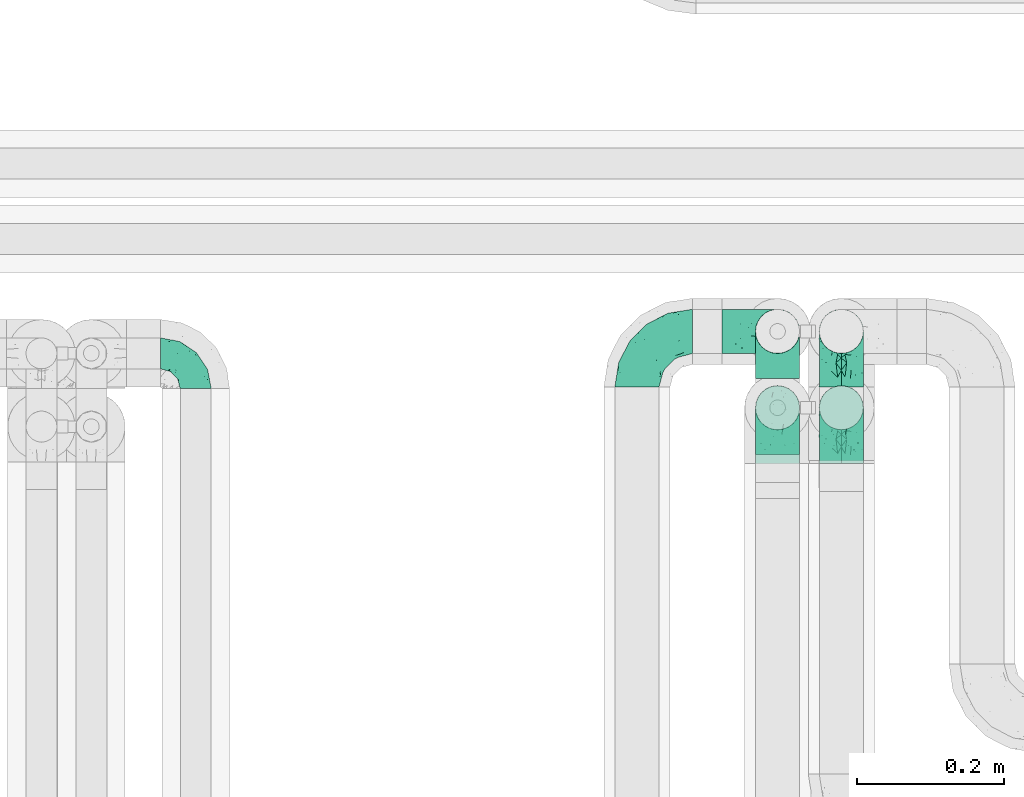
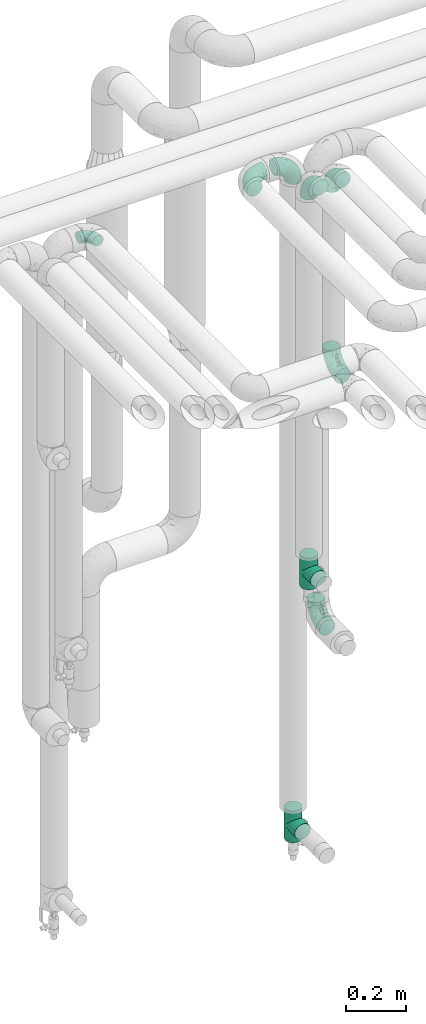
# One storey, part 639 of 827: 9 flow fittings.
"""IFC2X3 building model written with IfcOpenShell, lengths in millimetres."""

from ifc_helpers import new_model, entity, si_unit, converted_unit, derived_unit, direction, frame, origin, place, context, subcontext, project, spatial, faceted_brep, source, transform, mapped, material, type_object, type_shapes, element, save


model = new_model("IFC2X3")

# Units and contexts
model_context = context("Model", 3, precision=0.01, world=origin(), true_north=direction((6.12303176911189e-17, 1.0)))
body_context = subcontext(model_context, "Body", "Model", "MODEL_VIEW")
ifc_project = project(units=[si_unit("LENGTHUNIT", "METRE", prefix="MILLI"), si_unit("AREAUNIT", "SQUARE_METRE"), si_unit("VOLUMEUNIT", "CUBIC_METRE"), converted_unit("PLANEANGLEUNIT", "DEGREE", entity("IfcRatioMeasure", 0.0174532925199433), si_unit("PLANEANGLEUNIT", "RADIAN"), dimensions=[0, 0, 0, 0, 0, 0, 0]), si_unit("MASSUNIT", "GRAM", prefix="KILO"), derived_unit("MASSDENSITYUNIT", [(si_unit("MASSUNIT", "GRAM", prefix="KILO"), 1), (si_unit("LENGTHUNIT", "METRE"), -3)]), derived_unit("MOMENTOFINERTIAUNIT", [(si_unit("LENGTHUNIT", "METRE"), 4)]), si_unit("TIMEUNIT", "SECOND"), si_unit("FREQUENCYUNIT", "HERTZ"), si_unit("THERMODYNAMICTEMPERATUREUNIT", "DEGREE_CELSIUS"), derived_unit("THERMALTRANSMITTANCEUNIT", [(si_unit("MASSUNIT", "GRAM", prefix="KILO"), 1), (si_unit("THERMODYNAMICTEMPERATUREUNIT", "KELVIN"), -1), (si_unit("TIMEUNIT", "SECOND"), -3)]), derived_unit("VOLUMETRICFLOWRATEUNIT", [(si_unit("LENGTHUNIT", "METRE"), 3), (si_unit("TIMEUNIT", "SECOND"), -1)]), derived_unit("MASSFLOWRATEUNIT", [(si_unit("MASSUNIT", "GRAM", prefix="KILO"), 1), (si_unit("TIMEUNIT", "SECOND"), -1)]), derived_unit("ROTATIONALFREQUENCYUNIT", [(si_unit("TIMEUNIT", "SECOND"), -1)]), si_unit("ELECTRICCURRENTUNIT", "AMPERE"), si_unit("ELECTRICVOLTAGEUNIT", "VOLT"), si_unit("POWERUNIT", "WATT"), si_unit("FORCEUNIT", "NEWTON", prefix="KILO"), si_unit("ILLUMINANCEUNIT", "LUX"), si_unit("LUMINOUSFLUXUNIT", "LUMEN"), si_unit("LUMINOUSINTENSITYUNIT", "CANDELA"), derived_unit("USERDEFINED", [(si_unit("MASSUNIT", "GRAM", prefix="KILO"), -1), (si_unit("LENGTHUNIT", "METRE"), -2), (si_unit("TIMEUNIT", "SECOND"), 3), (si_unit("LUMINOUSFLUXUNIT", "LUMEN"), 1)]), derived_unit("LINEARVELOCITYUNIT", [(si_unit("LENGTHUNIT", "METRE"), 1), (si_unit("TIMEUNIT", "SECOND"), -1)]), si_unit("PRESSUREUNIT", "PASCAL"), derived_unit("USERDEFINED", [(si_unit("LENGTHUNIT", "METRE"), -2), (si_unit("MASSUNIT", "GRAM", prefix="KILO"), 1), (si_unit("TIMEUNIT", "SECOND"), -2)]), derived_unit("LINEARFORCEUNIT", [(si_unit("MASSUNIT", "GRAM", prefix="KILO"), 1), (si_unit("LENGTHUNIT", "METRE"), 1), (si_unit("TIMEUNIT", "SECOND"), -2), (si_unit("LENGTHUNIT", "METRE"), -1)]), derived_unit("PLANARFORCEUNIT", [(si_unit("MASSUNIT", "GRAM", prefix="KILO"), 1), (si_unit("LENGTHUNIT", "METRE"), 1), (si_unit("TIMEUNIT", "SECOND"), -2), (si_unit("LENGTHUNIT", "METRE"), -2)])], contexts=[model_context])

# Site, building, storey
site_placement = place(None, origin())
site = spatial("IfcSite", under=ifc_project, at=site_placement, CompositionType="ELEMENT")
building_placement = place(site_placement, origin())
building = spatial("IfcBuilding", under=site, at=building_placement, CompositionType="ELEMENT")
storey_placement = place(building_placement, frame((0.0, 0.0, 28200.0)))
storey = spatial("IfcBuildingStorey", under=building, at=storey_placement, Name="08", CompositionType="ELEMENT", Elevation=28200.0)

# Flow fittings
ifc_material = material()
pipe_fitting_type_1 = type_object("IfcPipeFittingType", Name="ADSK_1", PredefinedType="NOTDEFINED", material=ifc_material)
shared_shape_1 = source(origin(), body_context, "Body", "Brep", [
    faceted_brep([(-48.0, 10.6, -18.36), (-48.0, 5.49, -20.48), (-48.0, 0.0, -21.2), (-48.0, -5.49, -20.48), (-48.0, -10.6, -18.36), (-48.0, -14.99, -14.99), (-48.0, -18.36, -10.6), (-48.0, -20.48, -5.49), (-48.0, -21.2, 0.0), (-48.0, -20.48, 5.49), (-48.0, -18.36, 10.6), (-48.0, -14.99, 14.99), (-48.0, -10.6, 18.36), (-48.0, -5.49, 20.48), (-48.0, 0.0, 21.2), (-48.0, 5.49, 20.48), (-48.0, 10.6, 18.36), (-48.0, 14.99, 14.99), (-48.0, 18.36, 10.6), (-48.0, 20.48, 5.49), (-48.0, 21.2, 0.0), (-48.0, 20.48, -5.49), (-48.0, 18.36, -10.6), (-48.0, 14.99, -14.99), (0.0, 48.0, -21.2), (-5.49, 48.0, -20.48), (-10.6, 48.0, -18.36), (-14.99, 48.0, -14.99), (-18.36, 48.0, -10.6), (-20.48, 48.0, -5.49), (-21.2, 48.0, 0.0), (-20.48, 48.0, 5.49), (-18.36, 48.0, 10.6), (-14.99, 48.0, 14.99), (-10.6, 48.0, 18.36), (-5.49, 48.0, 20.48), (0.0, 48.0, 21.2), (5.49, 48.0, 20.48), (10.6, 48.0, 18.36), (14.99, 48.0, 14.99), (18.36, 48.0, 10.6), (20.48, 48.0, 5.49), (21.2, 48.0, 0.0), (20.48, 48.0, -5.49), (18.36, 48.0, -10.6), (14.99, 48.0, -14.99), (10.6, 48.0, -18.36), (5.49, 48.0, -20.48), (-35.25, -16.22, 12.01), (-34.76, -18.57, 0.0), (-20.87, -12.37, 10.9), (-31.49, -11.78, 15.9), (-37.0, -2.58, 20.86), (-33.89, 3.62, 21.15), (-31.81, -18.14, 6.76), (-5.78, 5.78, 17.67), (-19.42, -4.1, 17.86), (-9.6, -3.39, 13.73), (-35.44, -7.73, 19.13), (11.78, 31.49, 15.9), (-5.93, -5.46, 6.95), (-18.45, -13.78, 5.46), (-10.29, -8.43, 0.0), (-24.6, 0.55, 20.62), (-37.28, 17.94, 13.81), (-33.38, 22.85, 9.59), (-41.46, 20.06, 8.75), (-29.51, 20.45, 15.16), (-15.04, 10.79, 21.13), (-7.08, 16.98, 20.93), (-8.39, 23.51, 21.15), (-40.86, 13.03, 17.26), (-8.05, 41.26, 19.83), (-3.21, 35.97, 21.14), (8.53, 19.66, 14.74), (4.1, 19.42, 17.86), (-37.72, 22.66, 4.78), (-37.07, 8.58, 19.98), (-13.0, 5.43, 19.97), (-3.78, 13.93, 19.7), (3.02, 8.69, 13.43), (-2.27, -0.05, 10.65), (6.22, 6.99, 7.09), (-22.25, 34.6, 9.45), (18.14, 31.81, 6.76), (16.22, 35.25, 12.01), (12.37, 20.87, 10.9), (7.73, 35.44, 19.13), (-21.52, -15.93, 0.0), (2.58, 37.0, 20.86), (18.57, 34.76, 0.0), (13.78, 18.45, 5.46), (15.93, 21.52, 0.0), (-20.03, -8.54, 14.9), (-28.6, 28.6, 5.16), (-24.79, 34.6, 0.0), (-34.6, 24.79, 0.0), (-22.81, 37.41, 4.68), (-23.36, 26.33, 14.79), (-13.68, 37.05, 17.49), (-17.72, 38.12, 13.73), (-26.25, 27.3, 11.24), (-9.71, 32.34, 20.14), (-17.26, 25.6, 18.71), (-26.33, 9.99, 20.77), (-24.06, 6.05, 21.2), (-25.02, 15.46, 19.56), (-24.3, 20.72, 17.57), (-31.95, 15.23, 17.8), (-13.53, 24.7, 20.21), (-17.6, 17.6, 20.6), (-0.55, 24.6, 20.62), (-11.41, -7.48, 10.43), (0.93, -0.93, 0.0), (8.43, 10.29, 0.0), (-11.41, -7.48, -10.43), (-20.1, -8.84, -14.66), (-9.6, -3.39, -13.73), (7.73, 35.44, -19.13), (4.1, 19.42, -17.86), (-0.55, 24.6, -20.62), (-38.12, 17.72, -13.73), (-37.05, 13.68, -17.49), (-32.34, 9.71, -20.14), (-41.26, 8.05, -19.83), (-37.41, 22.81, -4.68), (-23.51, 8.39, -21.15), (-35.97, 3.21, -21.14), (-28.6, 28.6, -5.16), (-31.81, -18.14, -6.76), (-18.45, -13.78, -5.46), (-25.6, 17.26, -18.71), (-19.42, -4.1, -17.86), (-17.94, 37.28, -13.81), (-22.85, 33.38, -9.59), (-20.06, 41.46, -8.75), (-31.49, -11.78, -15.9), (-35.25, -16.22, -12.01), (8.53, 19.66, -14.74), (11.78, 31.49, -15.9), (-9.99, 26.33, -20.77), (-6.05, 24.06, -21.2), (-10.79, 15.04, -21.13), (-37.0, -2.58, -20.86), (-16.98, 7.08, -20.93), (-5.43, 13.0, -19.97), (-13.93, 3.78, -19.7), (-20.87, -12.37, -10.9), (-26.33, 23.36, -14.79), (-22.66, 37.72, -4.78), (13.78, 18.45, -5.46), (18.14, 31.81, -6.76), (-15.46, 25.02, -19.56), (-20.72, 24.3, -17.57), (16.22, 35.25, -12.01), (-13.03, 40.86, -17.26), (-8.58, 37.07, -19.98), (2.58, 37.0, -20.86), (-3.62, 33.89, -21.15), (-34.6, 22.25, -9.45), (6.22, 6.99, -7.09), (-20.45, 29.51, -15.16), (-35.44, -7.73, -19.13), (12.37, 20.87, -10.9), (-27.3, 26.25, -11.24), (-15.23, 31.95, -17.8), (-24.7, 13.53, -20.21), (-24.6, 0.55, -20.62), (-5.78, 5.78, -17.67), (-17.6, 17.6, -20.6), (3.02, 8.69, -13.43), (-5.93, -5.46, -6.95), (-2.27, -0.05, -10.65)], [[[0, 1, 2, 3, 4, 5, 6, 7, 8, 9, 10, 11, 12, 13, 14, 15, 16, 17, 18, 19, 20, 21, 22, 23]], [[24, 25, 26, 27, 28, 29, 30, 31, 32, 33, 34, 35, 36, 37, 38, 39, 40, 41, 42, 43, 44, 45, 46, 47]], [[10, 48, 11]], [[9, 8, 49]], [[48, 50, 51]], [[14, 52, 53]], [[10, 54, 48]], [[9, 54, 10]], [[55, 56, 57]], [[51, 12, 11]], [[51, 58, 12]], [[59, 39, 38]], [[60, 61, 62]], [[58, 56, 63]], [[64, 65, 66]], [[67, 65, 64]], [[68, 69, 70]], [[16, 71, 17]], [[13, 52, 14]], [[35, 72, 73]], [[14, 53, 15]], [[17, 64, 18]], [[74, 59, 75]], [[20, 19, 76]], [[66, 19, 18]], [[77, 15, 53]], [[15, 77, 16]], [[69, 78, 79]], [[80, 81, 82]], [[32, 31, 83]], [[84, 85, 86]], [[59, 87, 75]], [[61, 54, 88]], [[36, 89, 37]], [[84, 41, 40]], [[36, 35, 73]], [[90, 41, 84]], [[40, 39, 85]], [[12, 58, 13]], [[85, 84, 40]], [[91, 84, 86]], [[84, 92, 90]], [[87, 38, 37]], [[93, 56, 51]], [[65, 94, 76]], [[94, 95, 96]], [[84, 91, 92]], [[95, 97, 30]], [[98, 99, 100]], [[76, 94, 96]], [[101, 98, 83]], [[100, 99, 33]], [[102, 70, 73]], [[103, 102, 99]], [[94, 97, 95]], [[72, 99, 102]], [[72, 35, 34]], [[34, 33, 99]], [[9, 49, 54]], [[87, 59, 38]], [[104, 105, 68]], [[106, 103, 107]], [[106, 77, 104]], [[71, 64, 17]], [[108, 107, 67]], [[33, 32, 100]], [[109, 103, 110]], [[102, 109, 70]], [[89, 73, 111]], [[50, 48, 54]], [[51, 11, 48]], [[56, 58, 51]], [[88, 54, 49]], [[52, 58, 63]], [[50, 112, 93]], [[56, 55, 78]], [[39, 59, 85]], [[86, 85, 59]], [[89, 87, 37]], [[42, 41, 90]], [[111, 79, 75]], [[111, 75, 87]], [[75, 55, 80]], [[104, 77, 53]], [[71, 77, 108]], [[32, 83, 100]], [[98, 100, 83]], [[99, 98, 103]], [[106, 107, 108]], [[68, 70, 110]], [[111, 73, 70]], [[68, 110, 104]], [[68, 63, 78]], [[57, 93, 112]], [[80, 55, 57]], [[61, 50, 54]], [[80, 82, 86]], [[81, 57, 112]], [[74, 86, 59]], [[60, 113, 82]], [[82, 114, 91]], [[101, 94, 65]], [[97, 94, 83]], [[73, 89, 36]], [[87, 89, 111]], [[58, 52, 13]], [[53, 52, 63]], [[104, 53, 105]], [[106, 104, 110]], [[20, 76, 96]], [[76, 19, 66]], [[103, 106, 110]], [[77, 106, 108]], [[103, 98, 107]], [[67, 107, 98]], [[67, 98, 101]], [[108, 67, 64]], [[53, 63, 105]], [[63, 68, 105]], [[83, 31, 97]], [[30, 97, 31]], [[62, 113, 60]], [[112, 61, 60]], [[61, 88, 62]], [[86, 82, 91]], [[56, 78, 63]], [[114, 82, 113]], [[114, 92, 91]], [[79, 78, 55]], [[75, 79, 55]], [[69, 79, 111]], [[70, 69, 111]], [[78, 69, 68]], [[77, 71, 16]], [[64, 71, 108]], [[64, 66, 18]], [[76, 66, 65]], [[99, 72, 34]], [[73, 72, 102]], [[94, 101, 83]], [[67, 101, 65]], [[75, 80, 74]], [[80, 86, 74]], [[70, 109, 110]], [[102, 103, 109]], [[50, 93, 51]], [[57, 56, 93]], [[61, 112, 50]], [[81, 112, 60]], [[82, 81, 60]], [[80, 57, 81]], [[115, 116, 117]], [[118, 119, 120]], [[121, 122, 23]], [[123, 124, 122]], [[96, 125, 20]], [[123, 126, 127]], [[128, 96, 95]], [[129, 130, 88]], [[123, 122, 131]], [[116, 132, 117]], [[133, 134, 135]], [[0, 124, 1]], [[5, 136, 137]], [[138, 119, 139]], [[129, 88, 49]], [[140, 141, 142]], [[6, 5, 137]], [[46, 118, 47]], [[143, 3, 2]], [[144, 145, 146]], [[6, 129, 7]], [[129, 137, 147]], [[127, 2, 1]], [[148, 122, 121]], [[128, 125, 96]], [[134, 128, 149]], [[95, 149, 128]], [[150, 151, 92]], [[30, 29, 149]], [[152, 131, 153]], [[27, 133, 28]], [[154, 45, 44]], [[136, 5, 4]], [[27, 26, 155]], [[156, 26, 25]], [[24, 157, 158]], [[24, 47, 157]], [[22, 21, 159]], [[160, 150, 114]], [[134, 133, 161]], [[142, 144, 126]], [[46, 139, 118]], [[162, 136, 4]], [[156, 25, 158]], [[1, 124, 127]], [[115, 147, 116]], [[45, 154, 139]], [[139, 46, 45]], [[154, 163, 139]], [[162, 4, 3]], [[42, 90, 43]], [[130, 129, 147]], [[49, 7, 129]], [[43, 151, 44]], [[0, 23, 122]], [[24, 158, 25]], [[136, 162, 132]], [[135, 29, 28]], [[43, 90, 151]], [[164, 148, 159]], [[152, 156, 140]], [[155, 133, 27]], [[165, 153, 161]], [[23, 22, 121]], [[123, 131, 166]], [[123, 166, 126]], [[143, 127, 167]], [[147, 137, 136]], [[8, 7, 49]], [[129, 6, 137]], [[143, 162, 3]], [[167, 146, 132]], [[167, 132, 162]], [[132, 168, 117]], [[44, 151, 154]], [[92, 151, 90]], [[163, 154, 151]], [[119, 118, 139]], [[157, 118, 120]], [[138, 139, 163]], [[119, 168, 145]], [[140, 156, 158]], [[155, 156, 165]], [[22, 159, 121]], [[148, 121, 159]], [[122, 148, 131]], [[152, 153, 165]], [[142, 126, 169]], [[167, 127, 126]], [[142, 169, 140]], [[142, 120, 145]], [[168, 170, 117]], [[160, 171, 172]], [[115, 172, 171]], [[171, 62, 130]], [[119, 170, 168]], [[170, 163, 160]], [[150, 163, 151]], [[113, 171, 160]], [[164, 128, 134]], [[125, 128, 159]], [[127, 143, 2]], [[162, 143, 167]], [[118, 157, 47]], [[158, 157, 120]], [[140, 158, 141]], [[152, 140, 169]], [[30, 149, 95]], [[149, 29, 135]], [[131, 152, 169]], [[156, 152, 165]], [[131, 148, 153]], [[161, 153, 148]], [[161, 148, 164]], [[165, 161, 133]], [[158, 120, 141]], [[120, 142, 141]], [[159, 21, 125]], [[20, 125, 21]], [[115, 130, 147]], [[114, 113, 160]], [[62, 171, 113]], [[62, 88, 130]], [[160, 163, 150]], [[150, 92, 114]], [[119, 145, 120]], [[146, 145, 168]], [[132, 146, 168]], [[144, 146, 167]], [[126, 144, 167]], [[145, 144, 142]], [[156, 155, 26]], [[133, 155, 165]], [[133, 135, 28]], [[149, 135, 134]], [[122, 124, 0]], [[127, 124, 123]], [[128, 164, 159]], [[161, 164, 134]], [[163, 170, 138]], [[170, 119, 138]], [[131, 169, 166]], [[126, 166, 169]], [[147, 136, 116]], [[132, 116, 136]], [[172, 115, 117]], [[130, 115, 171]], [[117, 170, 172]], [[160, 172, 170]]]),
])
type_shapes(pipe_fitting_type_1, [shared_shape_1])
flow_fitting_placement = place(storey_placement, frame((30867.6, 18441.2, 3000.0), z_axis=(0.0, 0.0, 1.0), x_axis=(0.0, 1.0, 0.0)))
element("IfcFlowFitting", 1, at=flow_fitting_placement, inside=storey, type_object=pipe_fitting_type_1, material=ifc_material, Name="ADSK_1", ObjectType="ADSK_1", context=body_context, shape_type="MappedRepresentation", body=[
    mapped(shared_shape_1, transform((0.0, 0.0, 0.0), scale=1.0)),
])
pipe_fitting_type_2 = type_object("IfcPipeFittingType", Name="ADSK_1", PredefinedType="NOTDEFINED", material=ifc_material)
shared_shape_2 = source(origin(), body_context, "Body", "Brep", [
    faceted_brep([(-76.0, 15.07, -26.11), (-76.0, 7.8, -29.12), (-76.0, 0.0, -30.15), (-76.0, -7.8, -29.12), (-76.0, -15.08, -26.11), (-76.0, -21.32, -21.32), (-76.0, -26.11, -15.08), (-76.0, -29.12, -7.8), (-76.0, -30.15, 0.0), (-76.0, -29.12, 7.8), (-76.0, -26.11, 15.07), (-76.0, -21.32, 21.32), (-76.0, -15.08, 26.11), (-76.0, -7.8, 29.12), (-76.0, 0.0, 30.15), (-76.0, 7.8, 29.12), (-76.0, 15.07, 26.11), (-76.0, 21.32, 21.32), (-76.0, 26.11, 15.07), (-76.0, 29.12, 7.8), (-76.0, 30.15, 0.0), (-76.0, 29.12, -7.8), (-76.0, 26.11, -15.08), (-76.0, 21.32, -21.32), (0.0, 76.0, -30.15), (-7.8, 76.0, -29.12), (-15.07, 76.0, -26.11), (-21.32, 76.0, -21.32), (-26.11, 76.0, -15.08), (-29.12, 76.0, -7.8), (-30.15, 76.0, 0.0), (-29.12, 76.0, 7.8), (-26.11, 76.0, 15.07), (-21.32, 76.0, 21.32), (-15.07, 76.0, 26.11), (-7.8, 76.0, 29.12), (0.0, 76.0, 30.15), (7.8, 76.0, 29.12), (15.08, 76.0, 26.11), (21.32, 76.0, 21.32), (26.11, 76.0, 15.07), (29.12, 76.0, 7.8), (30.15, 76.0, 0.0), (29.12, 76.0, -7.8), (26.11, 76.0, -15.08), (21.32, 76.0, -21.32), (15.08, 76.0, -26.11), (7.8, 76.0, -29.12), (10.79, 31.43, 21.07), (4.32, 31.7, 25.72), (1.65, 15.19, 19.92), (-61.17, -27.8, 0.0), (-51.1, -25.49, 9.84), (-56.14, -10.61, 27.27), (-31.7, -4.32, 25.72), (-39.75, 1.72, 29.41), (-43.2, -24.95, 0.0), (-1.86, 1.86, 0.0), (4.49, 7.65, 5.78), (-7.82, -4.61, 5.83), (-56.21, -22.79, 17.21), (-58.98, -3.38, 29.7), (-53.96, 5.6, 30.07), (-10.86, 10.86, 25.48), (-17.2, -2.6, 20.44), (-49.15, -16.01, 22.7), (-22.18, -14.24, 7.99), (-28.4, -17.42, 0.0), (-13.61, -9.88, 0.0), (-39.0, 23.48, 27.76), (-58.76, 12.54, 28.36), (-41.61, 15.41, 29.48), (16.01, 49.15, 22.7), (-58.55, 25.93, 19.53), (-51.53, 33.5, 13.51), (-64.92, 28.76, 12.4), (-7.48, 23.14, 28.25), (-1.72, 39.75, 29.41), (-12.04, 27.88, 29.88), (-63.91, 18.81, 24.52), (-11.63, 65.16, 28.18), (-4.97, 57.02, 30.05), (9.88, 13.61, 0.0), (-62.5, 31.74, 5.02), (-45.17, 30.98, 21.2), (-21.78, 9.76, 28.58), (10.61, 56.14, 27.27), (-32.09, 54.42, 13.26), (22.79, 56.21, 17.21), (15.38, 31.17, 15.63), (25.49, 51.1, 9.84), (21.84, 36.35, 5.92), (24.95, 43.2, 0.0), (3.38, 58.98, 29.7), (-31.17, -15.38, 15.63), (-39.39, 41.78, 15.45), (-34.56, 41.13, 20.79), (-39.81, -23.25, 5.49), (27.8, 61.17, 0.0), (-31.74, 62.5, 5.02), (-53.07, 36.29, 0.0), (-42.95, 42.95, 7.29), (-36.29, 53.07, 0.0), (-19.83, 58.51, 24.79), (-25.48, 60.2, 19.41), (-14.53, 50.96, 28.57), (-13.31, 37.09, 30.07), (-26.16, 40.06, 26.4), (-32.43, -10.35, 21.9), (17.42, 28.4, 0.0), (14.24, 22.18, 7.99), (-38.67, 9.72, 30.15), (-24.66, 17.36, 30.09), (-37.08, 31.49, 24.99), (-49.27, 22.83, 25.24), (-20.8, 38.81, 28.63), (-27.58, 27.58, 29.2), (-36.07, -20.23, 10.71), (-15.19, -6.16, 14.9), (6.6, 15.4, 14.49), (-2.51, 2.51, 11.35), (-65.16, 11.63, -28.18), (-49.15, -16.01, -22.7), (-57.02, 4.97, -30.05), (-25.93, 58.55, -19.53), (-33.5, 51.53, -13.51), (-28.76, 64.92, -12.4), (-60.2, 25.48, -19.41), (-58.51, 19.83, -24.79), (4.61, 7.82, -5.83), (-7.65, -4.49, -5.78), (-2.51, 2.51, -11.35), (-62.5, 31.74, -5.02), (-50.96, 14.53, -28.57), (-37.09, 13.31, -30.07), (-42.95, 42.95, -7.29), (25.49, 51.1, -9.84), (22.79, 56.21, -17.21), (-40.06, 26.16, -26.4), (3.38, 58.98, -29.7), (-5.6, 53.96, -30.07), (-27.88, 12.04, -29.88), (-9.76, 21.78, -28.58), (-23.14, 7.48, -28.25), (-51.1, -25.49, -9.84), (15.38, 31.17, -15.63), (16.01, 49.15, -22.7), (-23.48, 39.0, -27.76), (-12.54, 58.76, -28.36), (-15.41, 41.61, -29.48), (-56.21, -22.79, -17.21), (-9.72, 38.67, -30.15), (-17.36, 24.66, -30.09), (-22.18, -14.24, -7.99), (-41.13, 34.56, -20.79), (-31.74, 62.5, -5.02), (-58.98, -3.38, -29.7), (-31.17, -15.38, -15.63), (-56.14, -10.61, -27.27), (14.24, 22.18, -7.99), (23.25, 39.81, -5.49), (-31.49, 37.08, -24.99), (-15.19, -6.16, -14.9), (1.65, 15.19, -19.92), (-18.81, 63.91, -24.52), (-32.59, -11.62, -20.84), (-31.7, -4.32, -25.72), (-17.2, -2.6, -20.44), (-39.75, 1.72, -29.41), (-54.42, 32.09, -13.26), (-30.98, 45.17, -21.2), (10.61, 56.14, -27.27), (10.23, 31.31, -21.52), (4.32, 31.7, -25.72), (-41.78, 39.39, -15.45), (-1.72, 39.75, -29.41), (-36.35, -21.84, -5.92), (-22.83, 49.27, -25.24), (-38.81, 20.8, -28.63), (-27.58, 27.58, -29.2), (-10.86, 10.86, -25.48), (20.23, 36.07, -10.71), (6.6, 15.4, -14.49)], [[[0, 1, 2, 3, 4, 5, 6, 7, 8, 9, 10, 11, 12, 13, 14, 15, 16, 17, 18, 19, 20, 21, 22, 23]], [[24, 25, 26, 27, 28, 29, 30, 31, 32, 33, 34, 35, 36, 37, 38, 39, 40, 41, 42, 43, 44, 45, 46, 47]], [[48, 49, 50]], [[51, 52, 9]], [[53, 54, 55]], [[9, 52, 10]], [[56, 52, 51]], [[57, 58, 59]], [[11, 10, 60]], [[14, 61, 62]], [[63, 54, 64]], [[65, 12, 11]], [[65, 53, 12]], [[66, 67, 68]], [[69, 70, 71]], [[72, 39, 38]], [[73, 74, 75]], [[15, 70, 16]], [[76, 77, 78]], [[16, 79, 17]], [[13, 61, 14]], [[35, 80, 81]], [[14, 62, 15]], [[17, 73, 18]], [[57, 82, 58]], [[20, 19, 83]], [[75, 19, 18]], [[70, 15, 62]], [[73, 84, 74]], [[78, 85, 76]], [[38, 86, 72]], [[32, 31, 87]], [[88, 89, 90]], [[91, 92, 90]], [[72, 86, 49]], [[36, 93, 37]], [[75, 83, 19]], [[36, 35, 81]], [[60, 94, 65]], [[40, 90, 41]], [[95, 96, 87]], [[88, 90, 40]], [[66, 97, 67]], [[90, 98, 41]], [[40, 39, 88]], [[99, 31, 30]], [[20, 83, 100]], [[101, 102, 100]], [[52, 60, 10]], [[102, 99, 30]], [[96, 103, 104]], [[83, 101, 100]], [[12, 53, 13]], [[104, 103, 33]], [[105, 106, 81]], [[107, 105, 103]], [[64, 54, 108]], [[80, 103, 105]], [[80, 35, 34]], [[34, 33, 103]], [[86, 38, 37]], [[109, 110, 82]], [[71, 111, 112]], [[69, 107, 113]], [[79, 73, 17]], [[114, 113, 84]], [[33, 32, 104]], [[115, 107, 116]], [[105, 115, 106]], [[93, 81, 77]], [[54, 53, 65]], [[61, 53, 55]], [[108, 94, 64]], [[54, 63, 85]], [[93, 86, 37]], [[77, 76, 49]], [[77, 49, 86]], [[49, 63, 50]], [[60, 52, 117]], [[65, 11, 60]], [[39, 72, 88]], [[89, 88, 72]], [[71, 70, 62]], [[79, 70, 114]], [[103, 96, 107]], [[69, 113, 114]], [[112, 106, 116]], [[77, 81, 106]], [[112, 116, 71]], [[112, 55, 85]], [[64, 50, 63]], [[57, 59, 68]], [[32, 87, 104]], [[96, 104, 87]], [[94, 118, 64]], [[50, 119, 89]], [[50, 64, 118]], [[50, 89, 48]], [[81, 93, 36]], [[86, 93, 77]], [[53, 61, 13]], [[62, 61, 55]], [[71, 62, 111]], [[69, 71, 116]], [[95, 101, 74]], [[99, 101, 87]], [[118, 66, 59]], [[117, 97, 66]], [[117, 66, 94]], [[91, 89, 110]], [[91, 110, 109]], [[110, 89, 119]], [[9, 8, 51]], [[98, 90, 92]], [[98, 42, 41]], [[101, 83, 74]], [[101, 99, 102]], [[87, 31, 99]], [[62, 55, 111]], [[55, 112, 111]], [[107, 69, 116]], [[70, 69, 114]], [[107, 96, 113]], [[84, 113, 96]], [[84, 96, 95]], [[114, 84, 73]], [[70, 79, 16]], [[73, 79, 114]], [[54, 85, 55]], [[76, 85, 63]], [[49, 76, 63]], [[77, 106, 78]], [[106, 112, 78]], [[85, 78, 112]], [[73, 75, 18]], [[83, 75, 74]], [[103, 80, 34]], [[81, 80, 105]], [[101, 95, 87]], [[84, 95, 74]], [[106, 115, 116]], [[105, 107, 115]], [[120, 59, 58]], [[82, 110, 58]], [[119, 58, 110]], [[118, 59, 120]], [[66, 68, 59]], [[54, 65, 108]], [[94, 108, 65]], [[66, 118, 94]], [[50, 118, 120]], [[50, 120, 119]], [[119, 120, 58]], [[89, 72, 48]], [[49, 48, 72]], [[60, 117, 94]], [[117, 52, 97]], [[52, 56, 97]], [[67, 97, 56]], [[92, 91, 109]], [[89, 91, 90]], [[121, 1, 0]], [[122, 5, 4]], [[2, 1, 123]], [[124, 125, 126]], [[127, 128, 23]], [[129, 130, 131]], [[100, 132, 20]], [[133, 134, 123]], [[135, 100, 102]], [[136, 137, 44]], [[133, 128, 138]], [[24, 139, 140]], [[141, 142, 143]], [[121, 128, 133]], [[6, 144, 7]], [[137, 145, 146]], [[144, 51, 7]], [[147, 148, 149]], [[144, 6, 150]], [[149, 151, 152]], [[153, 68, 67]], [[154, 128, 127]], [[30, 155, 102]], [[43, 42, 98]], [[156, 3, 2]], [[157, 144, 150]], [[158, 4, 3]], [[24, 140, 25]], [[155, 135, 102]], [[159, 160, 109]], [[30, 29, 155]], [[147, 138, 161]], [[27, 124, 28]], [[57, 129, 82]], [[162, 163, 131]], [[27, 26, 164]], [[148, 26, 25]], [[165, 166, 167]], [[24, 47, 139]], [[143, 168, 141]], [[22, 21, 169]], [[125, 124, 170]], [[148, 25, 140]], [[46, 146, 171]], [[158, 122, 4]], [[0, 23, 128]], [[1, 121, 123]], [[109, 82, 159]], [[45, 44, 137]], [[146, 46, 45]], [[136, 43, 98]], [[132, 21, 20]], [[136, 98, 92]], [[172, 173, 146]], [[46, 171, 47]], [[43, 136, 44]], [[174, 154, 169]], [[171, 173, 175]], [[6, 5, 150]], [[126, 29, 28]], [[176, 56, 144]], [[122, 158, 166]], [[164, 124, 27]], [[177, 161, 170]], [[23, 22, 127]], [[178, 138, 179]], [[133, 178, 134]], [[156, 123, 168]], [[156, 158, 3]], [[168, 143, 166]], [[168, 166, 158]], [[166, 180, 167]], [[173, 171, 146]], [[139, 171, 175]], [[172, 145, 163]], [[173, 180, 142]], [[5, 122, 150]], [[157, 150, 122]], [[137, 136, 181]], [[146, 45, 137]], [[149, 148, 140]], [[164, 148, 177]], [[128, 154, 138]], [[147, 161, 177]], [[152, 134, 179]], [[168, 123, 134]], [[152, 179, 149]], [[152, 175, 142]], [[57, 130, 129]], [[157, 165, 167]], [[22, 169, 127]], [[154, 127, 169]], [[163, 167, 180]], [[162, 157, 167]], [[173, 163, 180]], [[182, 163, 145]], [[123, 156, 2]], [[158, 156, 168]], [[171, 139, 47]], [[140, 139, 175]], [[149, 140, 151]], [[147, 149, 179]], [[174, 135, 125]], [[132, 135, 169]], [[176, 157, 153]], [[176, 153, 67]], [[153, 157, 162]], [[182, 159, 129]], [[181, 160, 159]], [[181, 159, 145]], [[51, 144, 56]], [[51, 8, 7]], [[135, 132, 100]], [[169, 21, 132]], [[126, 155, 29]], [[135, 155, 125]], [[140, 175, 151]], [[175, 152, 151]], [[138, 147, 179]], [[148, 147, 177]], [[138, 154, 161]], [[170, 161, 154]], [[170, 154, 174]], [[177, 170, 124]], [[148, 164, 26]], [[124, 164, 177]], [[173, 142, 175]], [[143, 142, 180]], [[166, 143, 180]], [[168, 134, 141]], [[134, 152, 141]], [[142, 141, 152]], [[124, 126, 28]], [[155, 126, 125]], [[128, 121, 0]], [[123, 121, 133]], [[135, 174, 169]], [[170, 174, 125]], [[134, 178, 179]], [[133, 138, 178]], [[130, 153, 162]], [[68, 153, 130]], [[57, 68, 130]], [[182, 129, 131]], [[159, 82, 129]], [[157, 122, 165]], [[166, 165, 122]], [[163, 162, 167]], [[162, 131, 130]], [[145, 172, 146]], [[163, 173, 172]], [[159, 182, 145]], [[131, 163, 182]], [[56, 176, 67]], [[157, 176, 144]], [[137, 181, 145]], [[181, 136, 160]], [[136, 92, 160]], [[109, 160, 92]]]),
])
type_shapes(pipe_fitting_type_2, [shared_shape_2])
for number, where, z_axis, x_axis, name in (
    (2, (31469.66, 18471.2, 3000.0), (0.0, 0.0, 1.0), (-1.0, 0.0, 0.0), "ADSK_1"),
    (3, (31661.66, 18471.2, 3000.0), (0.0, 1.0, 0.0), (1.0, 0.0, 0.0), "ADSK_1"),
    (4, (31748.66, 18471.2, 1120.13), (-1.0, 0.0, 0.0), (0.0, 0.0, -1.0), "ADSK_1"),
    (5, (31661.66, 18366.95, 3000.0), (-1.0, 0.0, 0.0), (0.0, 1.0, 0.0), "ADSK_1"),
    (6, (31748.66, 18366.95, 3000.0), (-1.0, 0.0, 0.0), (0.0, 1.0, 0.0), "ADSK_1"),
    (7, (31748.66, 18366.95, 2205.01), (-1.0, 0.0, 0.0), (0.0, 0.0, -1.0), "ADSK_1"),
):
    element("IfcFlowFitting", number, at=place(storey_placement, frame(where, z_axis=z_axis, x_axis=x_axis)), inside=storey, type_object=pipe_fitting_type_2, material=ifc_material, Name=name, ObjectType="ADSK_1", context=body_context, shape_type="MappedRepresentation", body=[
        mapped(shared_shape_2, transform((0.0, 0.0, 0.0), scale=1.0)),
    ])
pipe_fitting_type_3 = type_object("IfcPipeFittingType", Name="ADSK_1", PredefinedType="NOTDEFINED", material=ifc_material)
shared_shape_3 = source(origin(), body_context, "Body", "Brep", [
    faceted_brep([(-64.0, 15.07, -26.11), (-64.0, 7.8, -29.12), (-64.0, 0.0, -30.15), (-64.0, -7.8, -29.12), (-64.0, -15.08, -26.11), (-64.0, -21.32, -21.32), (-64.0, -26.11, -15.08), (-64.0, -29.12, -7.8), (-64.0, -30.15, 0.0), (-64.0, -29.12, 7.8), (-64.0, -26.11, 15.07), (-64.0, -21.32, 21.32), (-64.0, -15.08, 26.11), (-64.0, -7.8, 29.12), (-64.0, 0.0, 30.15), (-64.0, 7.8, 29.12), (-64.0, 15.07, 26.11), (-64.0, 21.32, 21.32), (-64.0, 26.11, 15.07), (-64.0, 29.12, 7.8), (-64.0, 30.15, 0.0), (-64.0, 29.12, -7.8), (-64.0, 26.11, -15.08), (-64.0, 21.32, -21.32), (64.0, 0.0, -30.15), (64.0, 7.8, -29.12), (64.0, 15.07, -26.11), (64.0, 21.32, -21.32), (64.0, 26.11, -15.08), (64.0, 29.12, -7.8), (64.0, 30.15, 0.0), (64.0, 29.12, 7.8), (64.0, 26.11, 15.07), (64.0, 21.32, 21.32), (64.0, 15.07, 26.11), (64.0, 7.8, 29.12), (64.0, 0.0, 30.15), (64.0, -7.8, 29.12), (64.0, -15.08, 26.11), (64.0, -21.32, 21.32), (64.0, -26.11, 15.07), (64.0, -29.12, 7.8), (64.0, -30.15, 0.0), (64.0, -29.12, -7.8), (64.0, -26.11, -15.08), (64.0, -21.32, -21.32), (64.0, -15.08, -26.11), (64.0, -7.8, -29.12), (29.06, -29.06, 8.05), (30.15, -30.15, 0.0), (-30.15, -30.15, 0.0), (26.09, -26.09, 15.1), (16.9, -16.9, 24.97), (21.88, -21.88, 20.75), (-29.06, -29.06, 8.05), (-26.09, -26.09, 15.1), (-21.88, -21.88, 20.75), (-16.9, -16.9, 24.97), (-11.47, -11.47, 27.88), (11.47, -11.47, 27.88), (5.79, -5.79, 29.59), (0.0, 0.0, 30.15), (-5.79, -5.79, 29.59), (5.79, -5.79, -29.59), (0.0, 0.0, -30.15), (-5.79, -5.79, -29.59), (-11.47, -11.47, -27.88), (11.47, -11.47, -27.88), (16.9, -16.9, -24.97), (21.88, -21.88, -20.75), (26.09, -26.09, -15.1), (29.06, -29.06, -8.05), (-16.9, -16.9, -24.97), (-21.88, -21.88, -20.75), (-29.06, -29.06, -8.05), (-26.09, -26.09, -15.1), (0.0, -64.0, -30.15), (7.8, -64.0, -29.12), (15.08, -64.0, -26.11), (21.32, -64.0, -21.32), (26.11, -64.0, -15.08), (29.12, -64.0, -7.8), (30.15, -64.0, 0.0), (29.12, -64.0, 7.8), (26.11, -64.0, 15.07), (21.32, -64.0, 21.32), (15.08, -64.0, 26.11), (7.8, -64.0, 29.12), (0.0, -64.0, 30.15), (-7.8, -64.0, 29.12), (-15.07, -64.0, 26.11), (-21.32, -64.0, 21.32), (-26.11, -64.0, 15.07), (-29.12, -64.0, 7.8), (-30.15, -64.0, 0.0), (-29.12, -64.0, -7.8), (-26.11, -64.0, -15.08), (-21.32, -64.0, -21.32), (-15.07, -64.0, -26.11), (-7.8, -64.0, -29.12)], [[[0, 1, 2, 3, 4, 5, 6, 7, 8, 9, 10, 11, 12, 13, 14, 15, 16, 17, 18, 19, 20, 21, 22, 23]], [[24, 25, 26, 27, 28, 29, 30, 31, 32, 33, 34, 35, 36, 37, 38, 39, 40, 41, 42, 43, 44, 45, 46, 47]], [[41, 40, 48]], [[42, 41, 49]], [[50, 9, 8]], [[49, 41, 48]], [[40, 51, 48]], [[39, 38, 52]], [[51, 40, 53]], [[52, 53, 39]], [[53, 40, 39]], [[50, 54, 9]], [[9, 54, 10]], [[54, 55, 10]], [[56, 57, 11]], [[11, 10, 56]], [[11, 57, 12]], [[56, 10, 55]], [[12, 57, 58]], [[52, 38, 59]], [[60, 36, 61]], [[62, 61, 14]], [[59, 37, 60]], [[37, 59, 38]], [[60, 37, 36]], [[61, 36, 35, 15, 14]], [[32, 31, 19, 18]], [[17, 16, 34, 33]], [[18, 17, 33, 32]], [[35, 34, 16, 15]], [[20, 19, 31, 30]], [[62, 13, 58]], [[13, 62, 14]], [[58, 13, 12]], [[27, 23, 22, 28]], [[22, 21, 29, 28]], [[0, 23, 27, 26]], [[20, 30, 29, 21]], [[24, 47, 63]], [[24, 64, 2, 1, 25]], [[64, 24, 63]], [[2, 64, 65]], [[26, 25, 1, 0]], [[65, 66, 3]], [[2, 65, 3]], [[66, 4, 3]], [[63, 47, 67]], [[46, 45, 68]], [[69, 68, 45]], [[44, 70, 69]], [[69, 45, 44]], [[46, 68, 67]], [[43, 42, 49]], [[7, 50, 8]], [[43, 71, 44]], [[71, 43, 49]], [[44, 71, 70]], [[72, 4, 66]], [[72, 5, 4]], [[5, 72, 73]], [[5, 73, 6]], [[74, 50, 7]], [[75, 74, 6]], [[74, 7, 6]], [[75, 6, 73]], [[46, 67, 47]], [[76, 77, 78, 79, 80, 81, 82, 83, 84, 85, 86, 87, 88, 89, 90, 91, 92, 93, 94, 95, 96, 97, 98, 99]], [[50, 94, 93]], [[54, 50, 93]], [[91, 90, 57]], [[56, 92, 91]], [[54, 93, 92]], [[58, 90, 89]], [[55, 54, 92]], [[56, 55, 92]], [[58, 57, 90]], [[88, 61, 62]], [[58, 89, 62]], [[56, 91, 57]], [[62, 89, 88]], [[60, 88, 87]], [[86, 59, 87]], [[84, 83, 48]], [[53, 85, 84]], [[52, 86, 85]], [[49, 83, 82]], [[59, 60, 87]], [[52, 59, 86]], [[49, 48, 83]], [[51, 53, 84]], [[48, 51, 84]], [[52, 85, 53]], [[88, 60, 61]], [[82, 81, 49]], [[71, 49, 81]], [[69, 80, 79]], [[79, 78, 68]], [[71, 81, 80]], [[67, 78, 77]], [[70, 71, 80]], [[69, 70, 80]], [[67, 68, 78]], [[76, 64, 63]], [[67, 77, 63]], [[69, 79, 68]], [[63, 77, 76]], [[65, 76, 99]], [[98, 66, 99]], [[96, 95, 74]], [[73, 97, 96]], [[72, 98, 97]], [[50, 95, 94]], [[66, 65, 99]], [[72, 66, 98]], [[50, 74, 95]], [[75, 73, 96]], [[74, 75, 96]], [[72, 97, 73]], [[76, 65, 64]]]),
])
type_shapes(pipe_fitting_type_3, [shared_shape_3])
for number, where, z_axis, x_axis, name in (
    (8, (31661.66, 18471.2, 315.5), (1.0, 0.0, 0.0), (0.0, 0.0, -1.0), "ADSK_1"),
    (9, (31661.66, 18366.95, 1405.5), (1.0, 0.0, 0.0), (0.0, 0.0, -1.0), "ADSK_1"),
):
    element("IfcFlowFitting", number, at=place(storey_placement, frame(where, z_axis=z_axis, x_axis=x_axis)), inside=storey, type_object=pipe_fitting_type_3, material=ifc_material, Name=name, ObjectType="ADSK_1", context=body_context, shape_type="MappedRepresentation", body=[
        mapped(shared_shape_3, transform((0.0, 0.0, 0.0), scale=1.0)),
    ])

save(model, "model.ifc")
